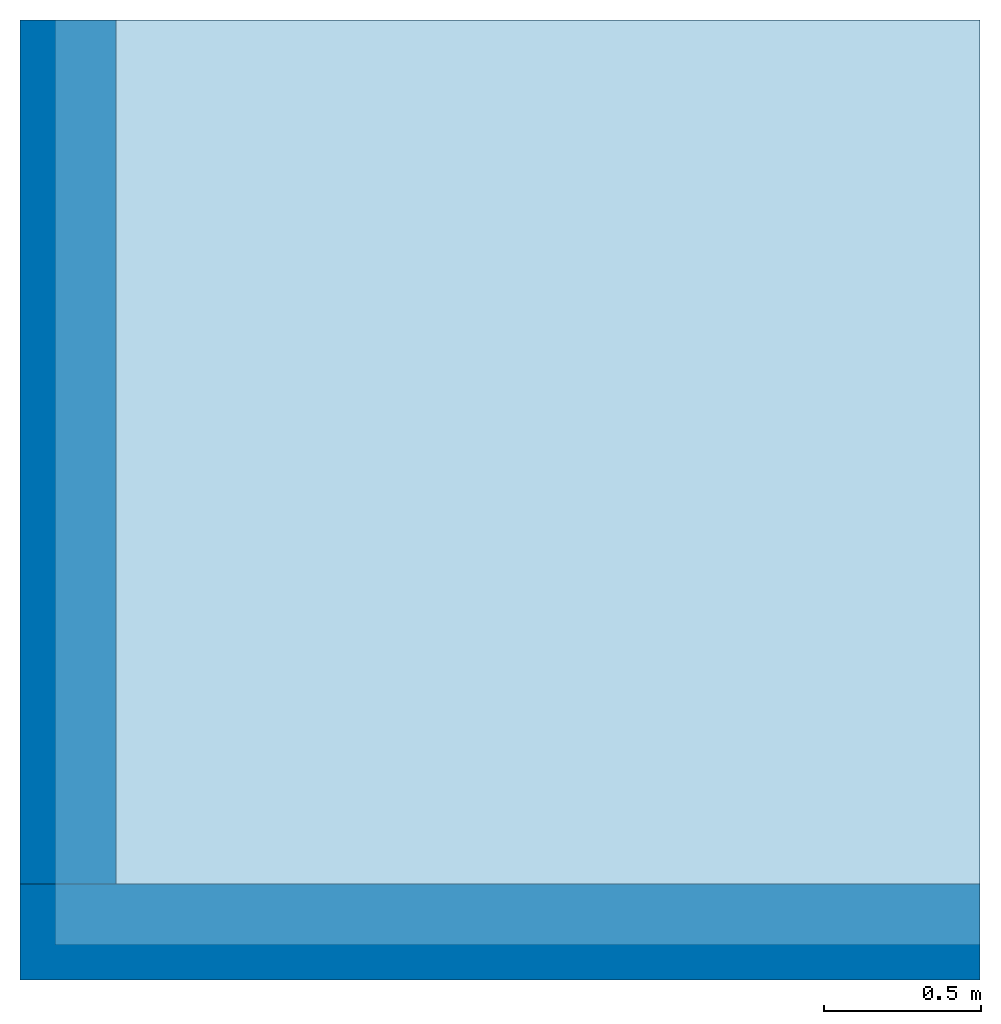
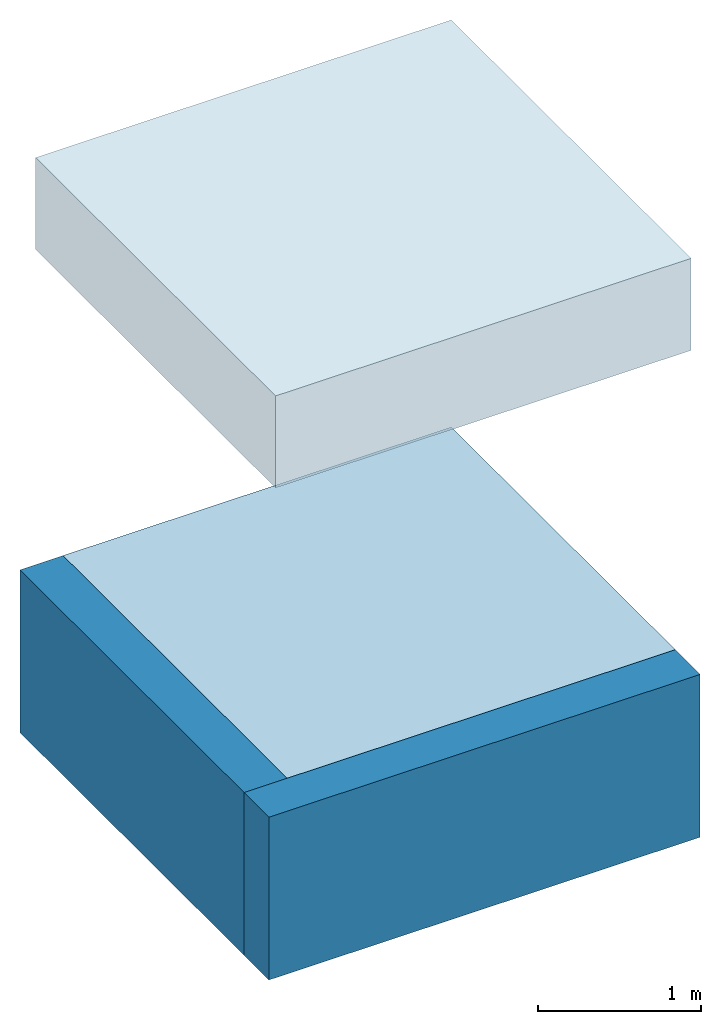
# One storey: 2 slabs, 2 walls.
"""IFC4 building model written with IfcOpenShell, lengths in feet."""

from ifc_helpers import new_model, entity, si_unit, converted_unit, frame, origin_with_axes, origin_2d_with_axis, place, context, subcontext, project, spatial, indexed_curve, outline, extrude, material, layer, layer_set, layer_usage, type_object, element, save


model = new_model("IFC4")

# Units and contexts
model_context = context("Model", 3, precision=1e-05, world=origin_with_axes())
plan_context = context("Plan", 2, precision=1e-05, world=origin_2d_with_axis())
body_context = subcontext(model_context, "Body", "Model", "MODEL_VIEW")
ifc_project = project(units=[converted_unit("PLANEANGLEUNIT", "degree", entity("IfcReal", 0.0174532925199433), si_unit("PLANEANGLEUNIT", "RADIAN"), dimensions=[0, 0, 0, 0, 0, 0, 0]), converted_unit("AREAUNIT", "square foot", entity("IfcReal", 0.09290304), si_unit("AREAUNIT", "SQUARE_METRE"), dimensions=[2, 0, 0, 0, 0, 0, 0]), converted_unit("LENGTHUNIT", "foot", entity("IfcReal", 0.3048), si_unit("LENGTHUNIT", "METRE"), dimensions=[1, 0, 0, 0, 0, 0, 0]), converted_unit("VOLUMEUNIT", "cubic foot", entity("IfcReal", 0.0283168467116885), si_unit("VOLUMEUNIT", "CUBIC_METRE"), dimensions=[3, 0, 0, 0, 0, 0, 0])], contexts=[model_context, plan_context])

# Site, building, storey
site_placement = place(None, origin_with_axes())
site = spatial("IfcSite", under=ifc_project, at=site_placement)
building_placement = place(site_placement, origin_with_axes())
building = spatial("IfcBuilding", under=site, at=building_placement, Name="Building")
storey_placement = place(building_placement, origin_with_axes())
storey = spatial("IfcBuildingStorey", under=building, at=storey_placement, Name="1st Floor")

# Slabs
ifc_material_1 = material(Category="Materials")
ifc_layer_1 = layer(ifc_material_1, 0.03125, Name="CARPET", Category="Materials")
ifc_material_2 = material(Category="Materials")
ifc_layer_2 = layer(ifc_material_2, 0.0625, Name="GYP. TOPPING", Category="Materials")
ifc_material_3 = material(Category="Materials")
ifc_layer_3 = layer(ifc_material_3, 0.0104166669771075, Name="SOUND MAT", Category="Materials")
ifc_material_4 = material(Category="Materials")
ifc_layer_4 = layer(ifc_material_4, 0.0625, Name="FLOOR SHEATHING", Category="Materials")
ifc_material_5 = material(Category="Materials")
ifc_layer_5 = layer(ifc_material_5, 2.0, Name="WOOD TRUSS", Category="Materials")
ifc_material_6 = material(Category="Materials")
ifc_layer_6 = layer(ifc_material_6, 0.0416666679084301, Name="RESILIENT CHANNEL", Category="Materials")
ifc_material_7 = material(Category="Materials")
ifc_layer_7 = layer(ifc_material_7, 0.0520833320915699, Name="GYP. BD", Category="Materials")
ifc_layer_set_1 = layer_set([ifc_layer_1, ifc_layer_2, ifc_layer_3, ifc_layer_4, ifc_layer_5, ifc_layer_6, ifc_layer_7], Name="Floor:FLOOR TRUSS")
ifc_layer_usage_1 = layer_usage(ifc_layer_set_1, "AXIS3", "POSITIVE", 0.0)
slab_type_1 = type_object("IfcSlabType", Name="Floor:FLOOR TRUSS", PredefinedType="FLOOR", material=ifc_layer_set_1)
slab_1_placement = place(storey_placement, frame((0.0, 0.0, 7.7395833383395), z_axis=(0.0, 0.0, 1.0), x_axis=(1.0, 0.0, 0.0)))
element("IfcSlab", 1, at=slab_1_placement, inside=storey, type_object=slab_type_1, material=ifc_layer_usage_1, Name="Slab", context=body_context, shape_type="SweptSolid", body=[
    extrude(outline(indexed_curve([(9.65625381469727, 9.65625095367432), (0.0, 9.65625095367432), (0.0, 0.0), (9.65625381469727, 0.0), (9.65625381469727, 9.65625095367432)])), None, (0.0, 0.0, 1.0), 2.26041666666667),
])
ifc_material_8 = material(Category="Materials")
ifc_layer_8 = layer(ifc_material_8, 0.333333343267441, Name="SLAB", Category="Materials")
ifc_material_9 = material(Name="RIGID INSULATION", Category="Materials")
ifc_layer_9 = layer(ifc_material_9, 0.16666667163372, Name="INSULATION")
ifc_material_10 = material(Category="Materials")
ifc_layer_10 = layer(ifc_material_10, 0.333333343267441, Name="SUB BASE", Category="Materials")
ifc_layer_set_2 = layer_set([ifc_layer_8, ifc_layer_9, ifc_layer_10], Name="Floor:CONCRETE SLAB - GRAVEL")
ifc_layer_usage_2 = layer_usage(ifc_layer_set_2, "AXIS3", "POSITIVE", 0.0)
slab_type_2 = type_object("IfcSlabType", Name="Floor:CONCRETE SLAB - GRAVEL", PredefinedType="FLOOR", material=ifc_layer_set_2)
slab_2_placement = place(storey_placement, frame((0.0, 1.95553296507187e-07, -0.833333359928582), z_axis=(0.0, 0.0, 1.0), x_axis=(1.0, 0.0, 0.0)))
element("IfcSlab", 2, at=slab_2_placement, inside=storey, type_object=slab_type_2, material=ifc_layer_usage_2, Name="Slab", context=body_context, shape_type="SweptSolid", body=[
    extrude(outline(indexed_curve([(9.65625476837158, 9.65625095367432), (9.65625476837158, 0.0), (0.0, 0.0), (0.0, 9.65625095367432), (9.65625476837158, 9.65625095367432)])), None, (0.0, 0.0, 1.0), 0.833333338300386),
])

# Walls
ifc_material_11 = material(Category="Materials")
ifc_layer_11 = layer(ifc_material_11, 0.833333313465118, Name="CONCRETE FOUNDATION", Category="Materials")
ifc_layer_12 = layer(ifc_material_9, 0.16666667163372, Name="INSULATION")
ifc_layer_set_3 = layer_set([ifc_layer_11, ifc_layer_12])
ifc_layer_usage_3 = layer_usage(ifc_layer_set_3, "AXIS2", "POSITIVE", 0.0)
wall_type = type_object("IfcWallType", PredefinedType="NOTDEFINED", material=ifc_layer_set_3)
wall_1_placement = place(storey_placement, frame((-0.364585948272014, 9.65625047683716, -3.99999965832928), z_axis=(0.0, 0.0, 1.0), x_axis=(3.13916473260163e-07, -0.999999999999951, 0.0)))
element("IfcWall", 3, at=wall_1_placement, inside=storey, type_object=wall_type, material=ifc_layer_usage_3, Name="Wall", context=body_context, shape_type="SweptSolid", body=[
    extrude(outline(indexed_curve([(0.0, 0.0), (0.0, 0.999999985098838), (9.02083220292939, 0.999999985098838), (9.02083220292939, 0.0), (0.0, 0.0)], self_intersect=False)), origin_with_axes(), (0.0, 0.0, 1.0), 4.00000004943587),
])
ifc_layer_usage_4 = layer_usage(ifc_layer_set_3, "AXIS2", "POSITIVE", 0.0)
wall_2_placement = place(storey_placement, frame((-0.364582794975108, -0.364582379424353, -3.99999926722269), z_axis=(0.0, 0.0, 1.0), x_axis=(0.999999999999936, 3.57627868652321e-07, 0.0)))
element("IfcWall", 4, at=wall_2_placement, inside=storey, type_object=wall_type, material=ifc_layer_usage_4, Name="Wall", context=body_context, shape_type="SweptSolid", body=[
    extrude(outline(indexed_curve([(0.0, 0.0), (0.0, 0.999999985098838), (10.0208363830318, 0.999999985098838), (10.0208363830318, 0.0), (0.0, 0.0)], self_intersect=False)), origin_with_axes(), (0.0, 0.0, 1.0), 4.00000004943587),
])

save(model, "model.ifc")
